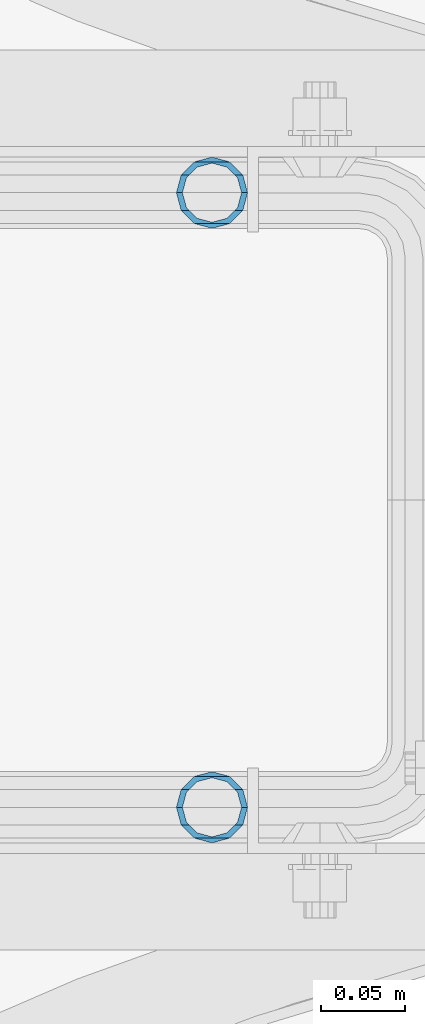
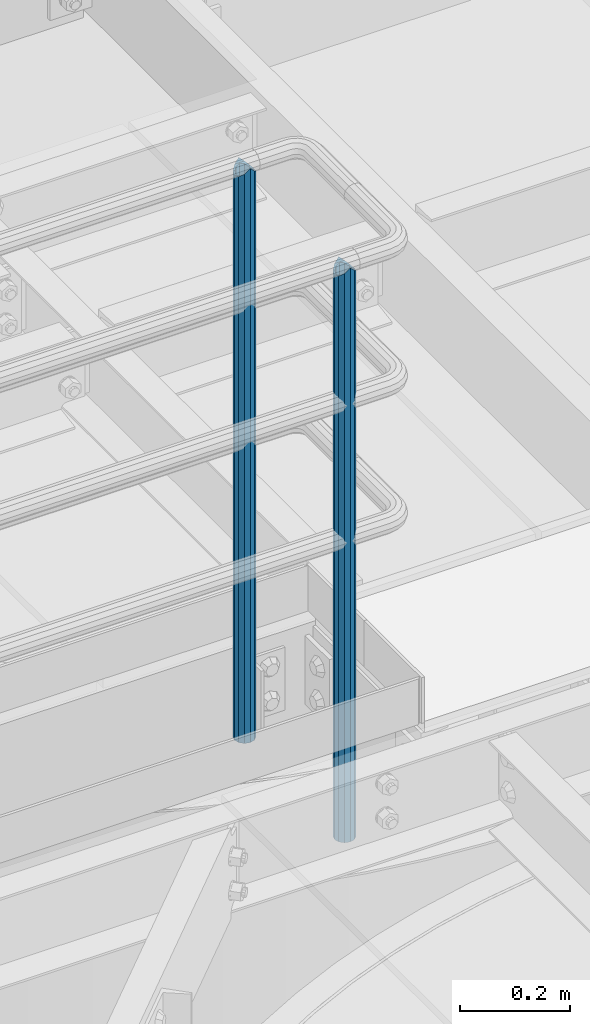
# One storey, part 551 of 1876: 2 columns, 2 elements without a shape of their own.
"""IFC2X3 building model written with IfcOpenShell, lengths in millimetres."""

from ifc_helpers import new_model, si_unit, frame, origin_with_axes, place, context, subcontext, project, spatial, faceted_brep, material, type_object, element, aggregate, save


model = new_model("IFC2X3")

# Units and contexts
model_context = context("Model", 3, precision=1e-05, world=origin_with_axes())
body_context = subcontext(model_context, "Body", "Model", "MODEL_VIEW")
ifc_project = project(units=[si_unit("LENGTHUNIT", "METRE", prefix="MILLI"), si_unit("AREAUNIT", "SQUARE_METRE"), si_unit("VOLUMEUNIT", "CUBIC_METRE"), si_unit("MASSUNIT", "GRAM", prefix="KILO"), si_unit("TIMEUNIT", "SECOND"), si_unit("PLANEANGLEUNIT", "RADIAN"), si_unit("SOLIDANGLEUNIT", "STERADIAN"), si_unit("THERMODYNAMICTEMPERATUREUNIT", "DEGREE_CELSIUS"), si_unit("LUMINOUSINTENSITYUNIT", "LUMEN")], contexts=[model_context])

# Site, building, storey
site_placement = place(None, origin_with_axes())
site = spatial("IfcSite", under=ifc_project, at=site_placement, CompositionType="ELEMENT")
building_placement = place(site_placement, origin_with_axes())
building = spatial("IfcBuilding", under=site, at=building_placement, Name="Undefined", CompositionType="ELEMENT")
storey_placement = place(building_placement, origin_with_axes())
storey = spatial("IfcBuildingStorey", under=building, at=storey_placement, Name="Undefined", CompositionType="ELEMENT", Elevation=0.0)

# Assembly, column
assembly_1_placement = place(storey_placement, origin_with_axes())
assembly_1 = element("IfcElementAssembly", 1, at=assembly_1_placement, inside=storey, Name="HANDRAIL", AssemblyPlace="NOTDEFINED", PredefinedType="RIGID_FRAME")
ifc_material = material()
column_type = type_object("IfcColumnType", Name="PIPE1-1/4STD", PredefinedType="NOTDEFINED")
column_1_placement = place(assembly_1_placement, frame((4572.00474593762, -11381.1963554687, 7813.675), z_axis=(0.0, 1.0, 0.0), x_axis=(0.0, 0.0, 1.0)))
column_1 = element("IfcColumn", 2, at=column_1_placement, type_object=column_type, material=ifc_material, Name="POST", ObjectType="PIPE1-1/4STD", context=body_context, shape_type="Brep", body=[
    faceted_brep([(1276.35, 0.0, -21.0820000000003), (1265.809, 10.5410000000002, -18.2575475625836), (1265.809, -10.5410000000002, -18.2575475625836), (1257.61603877328, 15.1779612267264, 8.76299999999992), (1255.268, 17.5259999999998, 0.0), (1255.268, 21.0820000000003, 0.0), (1258.09245243742, 18.2575475625836, 10.5410000000002), (1258.09245243742, 13.3999612267262, 10.5410000000002), (1258.09245243742, 13.3999612267262, -10.5410000000002), (1258.09245243742, 18.2575475625836, -10.5410000000002), (1257.61603877328, 15.1779612267264, -8.76299999999992), (1262.72937633681, 8.76299999999992, -15.1779612267255), (1265.07741511008, 0.0, -17.5259999999998), (1262.72937633681, -8.76299999999992, -15.1779612267255), (1258.09245243741, -13.3999612267244, -10.541000000002), (1258.09245243742, -18.2575475625836, -10.5409999999993), (1257.61602877145, -15.1779612267264, -8.76300000000083), (1255.268, -17.5259999999998, 0.0), (1255.268, -21.0820000000003, 0.0), (1257.61604877511, -15.1779612267264, 8.76300000000083), (1258.09245243741, -13.399961226728, 10.5409999999983), (1258.09245243742, -18.2575475625836, 10.5409999999993), (1276.35, 0.0, 21.0820000000003), (1265.809, -10.5410000000002, 18.2575475625836), (1265.809, 10.5410000000002, 18.2575475625836), (1262.72941366414, -8.76299999999992, 15.1779612267264), (1265.07745243742, 0.0, 17.5259999999998), (1262.72941366414, 8.76299999999992, 15.1779612267264), (0.0, -18.2575475625836, -10.5409999999993), (0.0, -10.5410000000002, -18.2575475625836), (-4.28826751885936e-09, 0.0, -21.0820000000003), (0.0, 10.5410000000002, -18.2575475625836), (0.0, 18.2575475625836, -10.5409999999993), (9.09494701772928e-13, 21.0820000000003, 0.0), (0.0, 18.2575475625836, 10.5409999999993), (0.0, 10.5410000000002, 18.2575475625836), (0.0, 0.0, 21.0820000000003), (0.0, -18.2575475625836, 10.5409999999993), (9.09494701772928e-13, -21.0820000000003, 0.0), (0.0, -10.5410000000002, 18.2575475625836), (0.0, -15.1779612267264, -8.76300000000083), (0.0, -8.76299999999992, -15.1779612267255), (0.0, 0.0, -17.5259999999998), (0.0, 8.76299999999992, -15.1779612267255), (0.0, 15.1779612267264, -8.76300000000083), (0.0, 17.5259999999998, 0.0), (0.0, 15.1779612267264, 8.76300000000083), (0.0, 8.76299999999992, 15.1779612267255), (0.0, 0.0, 17.5259999999998), (0.0, -8.76299999999992, 15.1779612267255), (0.0, -15.1779612267264, 8.76300000000083), (0.0, -17.5259999999998, 0.0)], [[[0, 1, 2]], [[3, 4, 5, 6, 7]], [[8, 9, 5, 4, 10]], [[2, 1, 9, 8, 11, 12, 13, 14, 15]], [[15, 14, 16, 17, 18]], [[18, 17, 19, 20, 21]], [[22, 23, 24]], [[21, 20, 25, 26, 27, 7, 6, 24, 23]], [[28, 29, 2, 15]], [[29, 30, 0, 2]], [[30, 31, 1, 0]], [[31, 32, 9, 1]], [[32, 33, 5, 9]], [[33, 34, 6, 5]], [[34, 35, 24, 6]], [[35, 36, 22, 24]], [[37, 38, 18, 21]], [[39, 37, 21, 23]], [[36, 39, 23, 22]], [[38, 28, 15, 18]], [[37, 39, 36, 35, 34, 33, 32, 31, 30, 29, 28, 38], [40, 41, 42, 43, 44, 45, 46, 47, 48, 49, 50, 51]], [[49, 48, 26, 25]], [[19, 50, 49, 25, 20]], [[51, 50, 19, 17]], [[40, 51, 17, 16]], [[41, 40, 16, 14, 13]], [[42, 41, 13, 12]], [[43, 42, 12, 11]], [[10, 44, 43, 11, 8]], [[45, 44, 10, 4]], [[46, 45, 4, 3]], [[47, 46, 3, 7, 27]], [[48, 47, 27, 26]]]),
])
aggregate(assembly_1, [column_1])

assembly_2_placement = place(storey_placement, origin_with_axes())
assembly_2 = element("IfcElementAssembly", 3, at=assembly_2_placement, inside=storey, Name="HANDRAIL", AssemblyPlace="NOTDEFINED", PredefinedType="RIGID_FRAME")
column_2_placement = place(assembly_2_placement, frame((4572.00143150122, -11745.4324531238, 7813.675), z_axis=(0.0, 1.0, 0.0), x_axis=(0.0, 0.0, 1.0)))
column_2 = element("IfcColumn", 4, at=column_2_placement, type_object=column_type, material=ifc_material, Name="POST", ObjectType="PIPE1-1/4STD", context=body_context, shape_type="Brep", body=[
    faceted_brep([(1276.35, 0.0, -21.0820000000003), (1265.809, 10.5410000000002, -18.2575475625836), (1265.809, -10.5410000000002, -18.2575475625836), (1257.61603877328, 15.1779612267264, 8.76299999999992), (1255.268, 17.5259999999998, 0.0), (1255.268, 21.0820000000003, 0.0), (1258.09245243742, 18.2575475625836, 10.5410000000002), (1258.09245243742, 13.3999612267262, 10.5410000000002), (1258.09245243742, 13.3999612267262, -10.5410000000002), (1258.09245243742, 18.2575475625836, -10.5410000000002), (1257.61603877328, 15.1779612267264, -8.76299999999992), (1262.72937633681, 8.76299999999992, -15.1779612267255), (1265.07741511008, 0.0, -17.5259999999998), (1262.72937633681, -8.76299999999992, -15.1779612267255), (1258.09245243741, -13.3999612267244, -10.541000000002), (1258.09245243742, -18.2575475625836, -10.5409999999993), (1257.61602877145, -15.1779612267264, -8.76300000000083), (1255.268, -17.5259999999998, 0.0), (1255.268, -21.0820000000003, 0.0), (1257.61604877511, -15.1779612267264, 8.76300000000083), (1258.09245243741, -13.399961226728, 10.5409999999983), (1258.09245243742, -18.2575475625836, 10.5409999999993), (1276.35, 0.0, 21.0820000000003), (1265.809, -10.5410000000002, 18.2575475625836), (1265.809, 10.5410000000002, 18.2575475625836), (1262.72941366414, -8.76299999999992, 15.1779612267264), (1265.07745243742, 0.0, 17.5259999999998), (1262.72941366414, 8.76299999999992, 15.1779612267264), (0.0, -18.2575475625836, -10.5409999999993), (0.0, -10.5410000000002, -18.2575475625836), (-4.28826751885936e-09, 0.0, -21.0820000000003), (0.0, 10.5410000000002, -18.2575475625836), (0.0, 18.2575475625836, -10.5409999999993), (9.09494701772928e-13, 21.0820000000003, 0.0), (0.0, 18.2575475625836, 10.5409999999993), (0.0, 10.5410000000002, 18.2575475625836), (0.0, 0.0, 21.0820000000003), (0.0, -18.2575475625836, 10.5409999999993), (9.09494701772928e-13, -21.0820000000003, 0.0), (0.0, -10.5410000000002, 18.2575475625836), (0.0, -15.1779612267264, -8.76300000000083), (0.0, -8.76299999999992, -15.1779612267255), (0.0, 0.0, -17.5259999999998), (0.0, 8.76299999999992, -15.1779612267255), (0.0, 15.1779612267264, -8.76300000000083), (0.0, 17.5259999999998, 0.0), (0.0, 15.1779612267264, 8.76300000000083), (0.0, 8.76299999999992, 15.1779612267255), (0.0, 0.0, 17.5259999999998), (0.0, -8.76299999999992, 15.1779612267255), (0.0, -15.1779612267264, 8.76300000000083), (0.0, -17.5259999999998, 0.0)], [[[0, 1, 2]], [[3, 4, 5, 6, 7]], [[8, 9, 5, 4, 10]], [[2, 1, 9, 8, 11, 12, 13, 14, 15]], [[15, 14, 16, 17, 18]], [[18, 17, 19, 20, 21]], [[22, 23, 24]], [[21, 20, 25, 26, 27, 7, 6, 24, 23]], [[28, 29, 2, 15]], [[29, 30, 0, 2]], [[30, 31, 1, 0]], [[31, 32, 9, 1]], [[32, 33, 5, 9]], [[33, 34, 6, 5]], [[34, 35, 24, 6]], [[35, 36, 22, 24]], [[37, 38, 18, 21]], [[39, 37, 21, 23]], [[36, 39, 23, 22]], [[38, 28, 15, 18]], [[37, 39, 36, 35, 34, 33, 32, 31, 30, 29, 28, 38], [40, 41, 42, 43, 44, 45, 46, 47, 48, 49, 50, 51]], [[49, 48, 26, 25]], [[19, 50, 49, 25, 20]], [[51, 50, 19, 17]], [[40, 51, 17, 16]], [[41, 40, 16, 14, 13]], [[42, 41, 13, 12]], [[43, 42, 12, 11]], [[10, 44, 43, 11, 8]], [[45, 44, 10, 4]], [[46, 45, 4, 3]], [[47, 46, 3, 7, 27]], [[48, 47, 27, 26]]]),
])
aggregate(assembly_2, [column_2])

save(model, "model.ifc")
